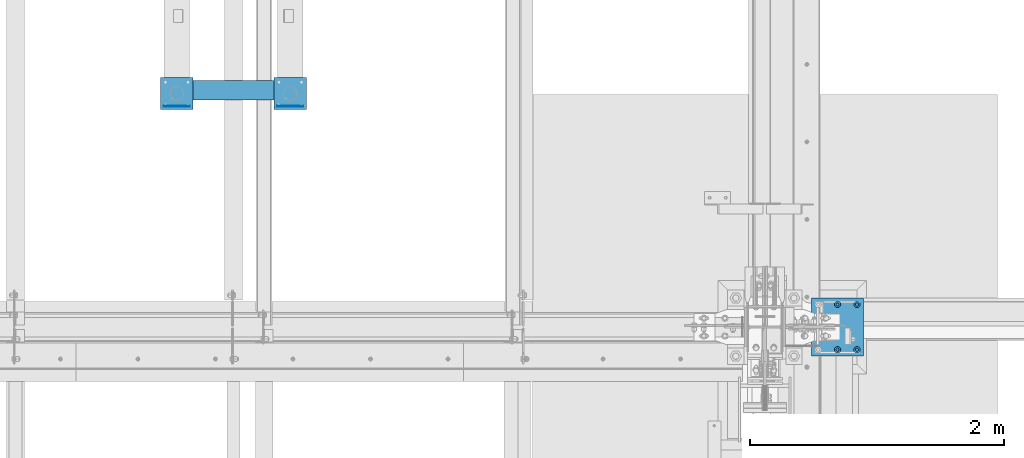
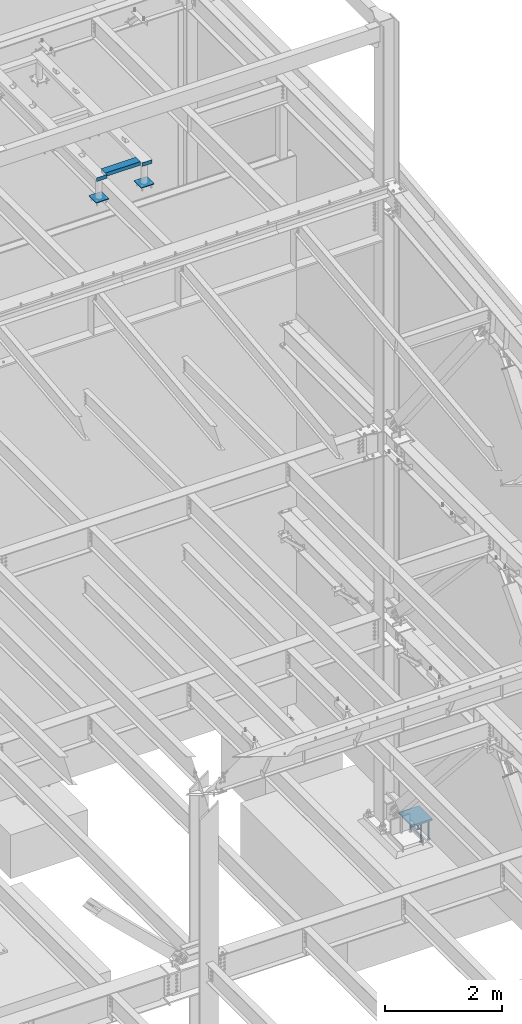
# One storey, part 900 of 1179: 10 beams, 2 elements without a shape of their own.
"""IFC2X3 building model written with IfcOpenShell, lengths in millimetres."""

from ifc_helpers import new_model, si_unit, frame, origin_with_axes, place, context, subcontext, project, spatial, faceted_brep, material, type_object, element, aggregate, save


model = new_model("IFC2X3")

# Units and contexts
model_context = context("Model", 3, precision=1e-05, world=origin_with_axes())
body_context = subcontext(model_context, "Body", "Model", "MODEL_VIEW")
ifc_project = project(units=[si_unit("LENGTHUNIT", "METRE", prefix="MILLI"), si_unit("AREAUNIT", "SQUARE_METRE"), si_unit("VOLUMEUNIT", "CUBIC_METRE"), si_unit("MASSUNIT", "GRAM", prefix="KILO"), si_unit("TIMEUNIT", "SECOND"), si_unit("PLANEANGLEUNIT", "RADIAN"), si_unit("SOLIDANGLEUNIT", "STERADIAN"), si_unit("THERMODYNAMICTEMPERATUREUNIT", "DEGREE_CELSIUS"), si_unit("LUMINOUSINTENSITYUNIT", "LUMEN")], contexts=[model_context])

# Site, building, storey
site_placement = place(None, origin_with_axes())
site = spatial("IfcSite", under=ifc_project, at=site_placement, CompositionType="ELEMENT")
building_placement = place(site_placement, origin_with_axes())
building = spatial("IfcBuilding", under=site, at=building_placement, Name="Undefined", CompositionType="ELEMENT")
storey_placement = place(building_placement, origin_with_axes())
storey = spatial("IfcBuildingStorey", under=building, at=storey_placement, Name="Undefined", CompositionType="ELEMENT", Elevation=0.0)

# Assembly, beams
assembly_1_placement = place(storey_placement, origin_with_axes())
assembly_1 = element("IfcElementAssembly", 1, at=assembly_1_placement, inside=storey, Name="FRAME", AssemblyPlace="NOTDEFINED", PredefinedType="RIGID_FRAME")
ifc_material_1 = material(Name="STEEL/A36")
beam_type_1 = type_object("IfcBeamType", PredefinedType="NOTDEFINED")
beam_1_placement = place(assembly_1_placement, frame((19581.8125, 36128.4035542222, 13722.35), z_axis=(0.0, 0.0, -1.0), x_axis=(1.0, 0.0, 0.0)))
beam_1 = element("IfcBeam", 2, at=beam_1_placement, type_object=beam_type_1, material=ifc_material_1, Name="PLATE", context=body_context, shape_type="Brep", body=[
    faceted_brep([(0.0, 2.38149999999951, -38.0999999999985), (0.0, 2.38149999999951, 38.0999999999985), (203.199999999997, 2.38150000000314, 38.1000000000004), (203.199999999997, 2.38150000000314, -38.1000000000004), (0.0, -2.38149999999951, 38.0999999999985), (203.199999999997, -2.38150000000314, 38.1000000000004), (0.0, -2.38149999999951, -38.0999999999985), (203.199999999997, -2.38150000000314, -38.1000000000004)], [[[0, 1, 2, 3]], [[1, 4, 5, 2]], [[4, 6, 7, 5]], [[6, 0, 3, 7]], [[5, 7, 3, 2]], [[6, 4, 1, 0]]]),
])
beam_2_placement = place(assembly_1_placement, frame((20473.9875, 36128.4035542222, 13722.35), z_axis=(0.0, 0.0, -1.0), x_axis=(1.0, 0.0, 0.0)))
beam_2 = element("IfcBeam", 3, at=beam_2_placement, type_object=beam_type_1, material=ifc_material_1, Name="PLATE", context=body_context, shape_type="Brep", body=[
    faceted_brep([(0.0, 2.38149999999951, -38.0999999999985), (0.0, 2.38149999999951, 38.0999999999985), (203.199999999997, 2.38150000000314, 38.1000000000004), (203.199999999997, 2.38150000000314, -38.1000000000004), (0.0, -2.38149999999951, 38.0999999999985), (203.199999999997, -2.38150000000314, 38.1000000000004), (0.0, -2.38149999999951, -38.0999999999985), (203.199999999997, -2.38150000000314, -38.1000000000004)], [[[0, 1, 2, 3]], [[1, 4, 5, 2]], [[4, 6, 7, 5]], [[6, 0, 3, 7]], [[5, 7, 3, 2]], [[6, 4, 1, 0]]]),
])
ifc_material_2 = material()
beam_type_2 = type_object("IfcBeamType", Name="HSS6X3X1/4", PredefinedType="NOTDEFINED")
beam_3_placement = place(assembly_1_placement, frame((19785.0125, 36253.0225542222, 13722.35), z_axis=(0.0, -1.0, 0.0), x_axis=(1.0, 0.0, 0.0)))
beam_3 = element("IfcBeam", 4, at=beam_3_placement, type_object=beam_type_2, material=ifc_material_2, Name="BEAM", ObjectType="HSS6X3X1/4", context=body_context, shape_type="Brep", body=[
    faceted_brep([(0.0, 31.75, -69.8499999999985), (0.0, -31.75, -69.8499999999985), (688.975000000006, -31.75, -69.8499999999985), (688.975000000006, 31.75, -69.8499999999985), (0.0, -31.75, 69.8499999999985), (688.975000000006, -31.75, 69.8499999999985), (0.0, 31.75, 69.8499999999985), (688.975000000006, 31.75, 69.8499999999985), (0.0, 38.0999999999985, -76.1999999999998), (0.0, 38.0999999999985, 76.1999999999998), (688.975000000006, 38.1000000000004, 76.1999999999971), (688.975000000006, 38.1000000000004, -76.1999999999971), (0.0, -38.0999999999985, 76.1999999999998), (688.975000000006, -38.1000000000004, 76.1999999999971), (0.0, -38.0999999999985, -76.1999999999998), (688.975000000006, -38.1000000000004, -76.1999999999971)], [[[0, 1, 2, 3]], [[1, 4, 5, 2]], [[4, 6, 7, 5]], [[6, 0, 3, 7]], [[8, 9, 10, 11]], [[9, 12, 13, 10]], [[12, 14, 15, 13]], [[14, 8, 11, 15]], [[13, 15, 11, 10], [5, 7, 3, 2]], [[14, 12, 9, 8], [6, 4, 1, 0]]]),
])
beam_type_3 = type_object("IfcBeamType", PredefinedType="NOTDEFINED")
beam_4_placement = place(assembly_1_placement, frame((20575.5875, 36100.6225542222, 13258.8), z_axis=(1.0, 0.0, 0.0), x_axis=(0.0, 1.0, 0.0)))
beam_4 = element("IfcBeam", 5, at=beam_4_placement, type_object=beam_type_3, material=ifc_material_1, Name="PLATE", context=body_context, shape_type="Brep", body=[
    faceted_brep([(0.0, 6.35000000000036, -127.0), (0.0, 6.34999999999854, 127.0), (254.0, 6.35000000000036, 127.0), (254.0, 6.35000000000036, -127.0), (0.0, -6.34999999999854, 127.0), (254.0, -6.35000000000036, 127.0), (0.0, -6.35000000000036, -127.0), (254.0, -6.35000000000036, -127.0)], [[[0, 1, 2, 3]], [[1, 4, 5, 2]], [[4, 6, 7, 5]], [[6, 0, 3, 7]], [[5, 7, 3, 2]], [[6, 4, 1, 0]]]),
])
beam_5_placement = place(assembly_1_placement, frame((19683.4125, 36100.6225542222, 13258.8), z_axis=(1.0, 0.0, 0.0), x_axis=(0.0, 1.0, 0.0)))
beam_5 = element("IfcBeam", 6, at=beam_5_placement, type_object=beam_type_3, material=ifc_material_1, Name="PLATE", context=body_context, shape_type="Brep", body=[
    faceted_brep([(0.0, 6.35000000000036, -127.0), (0.0, 6.34999999999854, 127.0), (254.0, 6.35000000000036, 127.0), (254.0, 6.35000000000036, -127.0), (0.0, -6.34999999999854, 127.0), (254.0, -6.35000000000036, 127.0), (0.0, -6.35000000000036, -127.0), (254.0, -6.35000000000036, -127.0)], [[[0, 1, 2, 3]], [[1, 4, 5, 2]], [[4, 6, 7, 5]], [[6, 0, 3, 7]], [[5, 7, 3, 2]], [[6, 4, 1, 0]]]),
])
aggregate(assembly_1, [beam_3, beam_1, beam_2, beam_4, beam_5])

assembly_2_placement = place(storey_placement, origin_with_axes())
assembly_2 = element("IfcElementAssembly", 7, at=assembly_2_placement, inside=storey, Name="EMBED_PLATE", AssemblyPlace="NOTDEFINED", PredefinedType="RIGID_FRAME")
ifc_material_3 = material(Name="STEEL/A108")
beam_type_4 = type_object("IfcBeamType", Name="STUD_1-DIA", PredefinedType="NOTDEFINED")
beam_6_placement = place(assembly_2_placement, frame((25031.7, 34569.4, -393.700006103516), z_axis=(1.0, 0.0, 0.0), x_axis=(0.0, 0.0, -1.0)))
beam_6 = element("IfcBeam", 8, at=beam_6_placement, type_object=beam_type_4, material=ifc_material_3, Name="STUD", ObjectType="STUD_1-DIA", context=body_context, shape_type="Brep", body=[
    faceted_brep([(0.0, -12.7, 0.0), (0.0, -11.0, -6.34999990463257), (382.016, -11.0, -6.34999990463257), (382.016, -12.6999998092651, 0.0), (0.0, -6.34999990463257, -11.0), (382.016, -6.34999990463257, -11.0), (0.0, 0.0, -12.6999998092651), (382.016, 0.0, -12.6999998092651), (0.0, 6.34999990463257, -11.0), (382.016, 6.34999990463257, -11.0), (0.0, 11.0, -6.34999990463257), (382.016, 11.0, -6.34999990463257), (0.0, 12.7, 0.0), (382.016, 12.6999998092651, 0.0), (0.0, 11.0, 6.34999990463257), (382.016, 11.0, 6.34999990463257), (0.0, 6.34999990463257, 11.0), (382.016, 6.34999990463257, 11.0), (0.0, 0.0, 12.6999998092651), (382.016, 0.0, 12.6999998092651), (0.0, -6.34999990463257, 11.0), (382.016, -6.34999990463257, 11.0), (0.0, -11.0, 6.34999990463257), (382.016, -11.0, 6.34999990463257), (386.08, -22.0, -12.6999998092651), (386.08, -25.3999996185303, 0.0), (386.08, -12.6999998092651, -22.0), (386.08, 0.0, -25.3999996185303), (386.08, 12.6999998092651, -22.0), (386.08, 22.0, -12.6999998092651), (386.08, 25.3999996185303, 0.0), (386.08, 22.0, 12.6999998092651), (386.08, 12.6999998092651, 22.0), (386.08, 0.0, 25.3999996185303), (386.08, -12.6999998092651, 22.0), (386.08, -22.0, 12.6999998092651), (406.4, -22.0, -12.6999998092651), (406.4, -25.3999996185303, 0.0), (406.4, -12.6999998092651, -22.0), (406.4, 0.0, -25.3999996185303), (406.4, 12.6999998092651, -22.0), (406.4, 22.0, -12.6999998092651), (406.4, 25.3999996185303, 0.0), (406.4, 22.0, 12.6999998092651), (406.4, 12.6999998092651, 22.0), (406.4, 0.0, 25.3999996185303), (406.4, -12.6999998092651, 22.0), (406.4, -22.0, 12.6999998092651)], [[[0, 1, 2, 3]], [[1, 4, 5, 2]], [[4, 6, 7, 5]], [[6, 8, 9, 7]], [[8, 10, 11, 9]], [[10, 12, 13, 11]], [[12, 14, 15, 13]], [[14, 16, 17, 15]], [[16, 18, 19, 17]], [[18, 20, 21, 19]], [[20, 22, 23, 21]], [[22, 0, 3, 23]], [[22, 20, 18, 16, 14, 12, 10, 8, 6, 4, 1, 0]], [[3, 2, 24, 25]], [[2, 5, 26, 24]], [[5, 7, 27, 26]], [[7, 9, 28, 27]], [[9, 11, 29, 28]], [[11, 13, 30, 29]], [[13, 15, 31, 30]], [[15, 17, 32, 31]], [[17, 19, 33, 32]], [[19, 21, 34, 33]], [[21, 23, 35, 34]], [[23, 3, 25, 35]], [[25, 24, 36, 37]], [[24, 26, 38, 36]], [[26, 27, 39, 38]], [[27, 28, 40, 39]], [[28, 29, 41, 40]], [[29, 30, 42, 41]], [[30, 31, 43, 42]], [[31, 32, 44, 43]], [[32, 33, 45, 44]], [[33, 34, 46, 45]], [[34, 35, 47, 46]], [[35, 25, 37, 47]], [[38, 39, 40, 41, 42, 43, 44, 45, 46, 47, 37, 36]]]),
])
beam_7_placement = place(assembly_2_placement, frame((24879.3, 34569.4, -393.700006103516), z_axis=(1.0, 0.0, 0.0), x_axis=(0.0, 0.0, -1.0)))
beam_7 = element("IfcBeam", 9, at=beam_7_placement, type_object=beam_type_4, material=ifc_material_3, Name="STUD", ObjectType="STUD_1-DIA", context=body_context, shape_type="Brep", body=[
    faceted_brep([(0.0, -12.7, 0.0), (0.0, -11.0, -6.34999990463257), (382.016, -11.0, -6.34999990463257), (382.016, -12.6999998092651, 0.0), (0.0, -6.34999990463257, -11.0), (382.016, -6.34999990463257, -11.0), (0.0, 0.0, -12.6999998092651), (382.016, 0.0, -12.6999998092651), (0.0, 6.34999990463257, -11.0), (382.016, 6.34999990463257, -11.0), (0.0, 11.0, -6.34999990463257), (382.016, 11.0, -6.34999990463257), (0.0, 12.7, 0.0), (382.016, 12.6999998092651, 0.0), (0.0, 11.0, 6.34999990463257), (382.016, 11.0, 6.34999990463257), (0.0, 6.34999990463257, 11.0), (382.016, 6.34999990463257, 11.0), (0.0, 0.0, 12.6999998092651), (382.016, 0.0, 12.6999998092651), (0.0, -6.34999990463257, 11.0), (382.016, -6.34999990463257, 11.0), (0.0, -11.0, 6.34999990463257), (382.016, -11.0, 6.34999990463257), (386.08, -22.0, -12.6999998092651), (386.08, -25.3999996185303, 0.0), (386.08, -12.6999998092651, -22.0), (386.08, 0.0, -25.3999996185303), (386.08, 12.6999998092651, -22.0), (386.08, 22.0, -12.6999998092651), (386.08, 25.3999996185303, 0.0), (386.08, 22.0, 12.6999998092651), (386.08, 12.6999998092651, 22.0), (386.08, 0.0, 25.3999996185303), (386.08, -12.6999998092651, 22.0), (386.08, -22.0, 12.6999998092651), (406.4, -22.0, -12.6999998092651), (406.4, -25.3999996185303, 0.0), (406.4, -12.6999998092651, -22.0), (406.4, 0.0, -25.3999996185303), (406.4, 12.6999998092651, -22.0), (406.4, 22.0, -12.6999998092651), (406.4, 25.3999996185303, 0.0), (406.4, 22.0, 12.6999998092651), (406.4, 12.6999998092651, 22.0), (406.4, 0.0, 25.3999996185303), (406.4, -12.6999998092651, 22.0), (406.4, -22.0, 12.6999998092651)], [[[0, 1, 2, 3]], [[1, 4, 5, 2]], [[4, 6, 7, 5]], [[6, 8, 9, 7]], [[8, 10, 11, 9]], [[10, 12, 13, 11]], [[12, 14, 15, 13]], [[14, 16, 17, 15]], [[16, 18, 19, 17]], [[18, 20, 21, 19]], [[20, 22, 23, 21]], [[22, 0, 3, 23]], [[22, 20, 18, 16, 14, 12, 10, 8, 6, 4, 1, 0]], [[3, 2, 24, 25]], [[2, 5, 26, 24]], [[5, 7, 27, 26]], [[7, 9, 28, 27]], [[9, 11, 29, 28]], [[11, 13, 30, 29]], [[13, 15, 31, 30]], [[15, 17, 32, 31]], [[17, 19, 33, 32]], [[19, 21, 34, 33]], [[21, 23, 35, 34]], [[23, 3, 25, 35]], [[25, 24, 36, 37]], [[24, 26, 38, 36]], [[26, 27, 39, 38]], [[27, 28, 40, 39]], [[28, 29, 41, 40]], [[29, 30, 42, 41]], [[30, 31, 43, 42]], [[31, 32, 44, 43]], [[32, 33, 45, 44]], [[33, 34, 46, 45]], [[34, 35, 47, 46]], [[35, 25, 37, 47]], [[38, 39, 40, 41, 42, 43, 44, 45, 46, 47, 37, 36]]]),
])
beam_8_placement = place(assembly_2_placement, frame((25031.7, 34213.8, -393.700006103516), z_axis=(1.0, 0.0, 0.0), x_axis=(0.0, 0.0, -1.0)))
beam_8 = element("IfcBeam", 10, at=beam_8_placement, type_object=beam_type_4, material=ifc_material_3, Name="STUD", ObjectType="STUD_1-DIA", context=body_context, shape_type="Brep", body=[
    faceted_brep([(0.0, -12.7, 0.0), (0.0, -11.0, -6.34999990463257), (382.016, -11.0, -6.34999990463257), (382.016, -12.6999998092651, 0.0), (0.0, -6.34999990463257, -11.0), (382.016, -6.34999990463257, -11.0), (0.0, 0.0, -12.6999998092651), (382.016, 0.0, -12.6999998092651), (0.0, 6.34999990463257, -11.0), (382.016, 6.34999990463257, -11.0), (0.0, 11.0, -6.34999990463257), (382.016, 11.0, -6.34999990463257), (0.0, 12.7, 0.0), (382.016, 12.6999998092651, 0.0), (0.0, 11.0, 6.34999990463257), (382.016, 11.0, 6.34999990463257), (0.0, 6.34999990463257, 11.0), (382.016, 6.34999990463257, 11.0), (0.0, 0.0, 12.6999998092651), (382.016, 0.0, 12.6999998092651), (0.0, -6.34999990463257, 11.0), (382.016, -6.34999990463257, 11.0), (0.0, -11.0, 6.34999990463257), (382.016, -11.0, 6.34999990463257), (386.08, -22.0, -12.6999998092651), (386.08, -25.3999996185303, 0.0), (386.08, -12.6999998092651, -22.0), (386.08, 0.0, -25.3999996185303), (386.08, 12.6999998092651, -22.0), (386.08, 22.0, -12.6999998092651), (386.08, 25.3999996185303, 0.0), (386.08, 22.0, 12.6999998092651), (386.08, 12.6999998092651, 22.0), (386.08, 0.0, 25.3999996185303), (386.08, -12.6999998092651, 22.0), (386.08, -22.0, 12.6999998092651), (406.4, -22.0, -12.6999998092651), (406.4, -25.3999996185303, 0.0), (406.4, -12.6999998092651, -22.0), (406.4, 0.0, -25.3999996185303), (406.4, 12.6999998092651, -22.0), (406.4, 22.0, -12.6999998092651), (406.4, 25.3999996185303, 0.0), (406.4, 22.0, 12.6999998092651), (406.4, 12.6999998092651, 22.0), (406.4, 0.0, 25.3999996185303), (406.4, -12.6999998092651, 22.0), (406.4, -22.0, 12.6999998092651)], [[[0, 1, 2, 3]], [[1, 4, 5, 2]], [[4, 6, 7, 5]], [[6, 8, 9, 7]], [[8, 10, 11, 9]], [[10, 12, 13, 11]], [[12, 14, 15, 13]], [[14, 16, 17, 15]], [[16, 18, 19, 17]], [[18, 20, 21, 19]], [[20, 22, 23, 21]], [[22, 0, 3, 23]], [[22, 20, 18, 16, 14, 12, 10, 8, 6, 4, 1, 0]], [[3, 2, 24, 25]], [[2, 5, 26, 24]], [[5, 7, 27, 26]], [[7, 9, 28, 27]], [[9, 11, 29, 28]], [[11, 13, 30, 29]], [[13, 15, 31, 30]], [[15, 17, 32, 31]], [[17, 19, 33, 32]], [[19, 21, 34, 33]], [[21, 23, 35, 34]], [[23, 3, 25, 35]], [[25, 24, 36, 37]], [[24, 26, 38, 36]], [[26, 27, 39, 38]], [[27, 28, 40, 39]], [[28, 29, 41, 40]], [[29, 30, 42, 41]], [[30, 31, 43, 42]], [[31, 32, 44, 43]], [[32, 33, 45, 44]], [[33, 34, 46, 45]], [[34, 35, 47, 46]], [[35, 25, 37, 47]], [[38, 39, 40, 41, 42, 43, 44, 45, 46, 47, 37, 36]]]),
])
beam_9_placement = place(assembly_2_placement, frame((24879.3, 34213.8, -393.700006103516), z_axis=(1.0, 0.0, 0.0), x_axis=(0.0, 0.0, -1.0)))
beam_9 = element("IfcBeam", 11, at=beam_9_placement, type_object=beam_type_4, material=ifc_material_3, Name="STUD", ObjectType="STUD_1-DIA", context=body_context, shape_type="Brep", body=[
    faceted_brep([(0.0, -12.7, 0.0), (0.0, -11.0, -6.34999990463257), (382.016, -11.0, -6.34999990463257), (382.016, -12.6999998092651, 0.0), (0.0, -6.34999990463257, -11.0), (382.016, -6.34999990463257, -11.0), (0.0, 0.0, -12.6999998092651), (382.016, 0.0, -12.6999998092651), (0.0, 6.34999990463257, -11.0), (382.016, 6.34999990463257, -11.0), (0.0, 11.0, -6.34999990463257), (382.016, 11.0, -6.34999990463257), (0.0, 12.7, 0.0), (382.016, 12.6999998092651, 0.0), (0.0, 11.0, 6.34999990463257), (382.016, 11.0, 6.34999990463257), (0.0, 6.34999990463257, 11.0), (382.016, 6.34999990463257, 11.0), (0.0, 0.0, 12.6999998092651), (382.016, 0.0, 12.6999998092651), (0.0, -6.34999990463257, 11.0), (382.016, -6.34999990463257, 11.0), (0.0, -11.0, 6.34999990463257), (382.016, -11.0, 6.34999990463257), (386.08, -22.0, -12.6999998092651), (386.08, -25.3999996185303, 0.0), (386.08, -12.6999998092651, -22.0), (386.08, 0.0, -25.3999996185303), (386.08, 12.6999998092651, -22.0), (386.08, 22.0, -12.6999998092651), (386.08, 25.3999996185303, 0.0), (386.08, 22.0, 12.6999998092651), (386.08, 12.6999998092651, 22.0), (386.08, 0.0, 25.3999996185303), (386.08, -12.6999998092651, 22.0), (386.08, -22.0, 12.6999998092651), (406.4, -22.0, -12.6999998092651), (406.4, -25.3999996185303, 0.0), (406.4, -12.6999998092651, -22.0), (406.4, 0.0, -25.3999996185303), (406.4, 12.6999998092651, -22.0), (406.4, 22.0, -12.6999998092651), (406.4, 25.3999996185303, 0.0), (406.4, 22.0, 12.6999998092651), (406.4, 12.6999998092651, 22.0), (406.4, 0.0, 25.3999996185303), (406.4, -12.6999998092651, 22.0), (406.4, -22.0, 12.6999998092651)], [[[0, 1, 2, 3]], [[1, 4, 5, 2]], [[4, 6, 7, 5]], [[6, 8, 9, 7]], [[8, 10, 11, 9]], [[10, 12, 13, 11]], [[12, 14, 15, 13]], [[14, 16, 17, 15]], [[16, 18, 19, 17]], [[18, 20, 21, 19]], [[20, 22, 23, 21]], [[22, 0, 3, 23]], [[22, 20, 18, 16, 14, 12, 10, 8, 6, 4, 1, 0]], [[3, 2, 24, 25]], [[2, 5, 26, 24]], [[5, 7, 27, 26]], [[7, 9, 28, 27]], [[9, 11, 29, 28]], [[11, 13, 30, 29]], [[13, 15, 31, 30]], [[15, 17, 32, 31]], [[17, 19, 33, 32]], [[19, 21, 34, 33]], [[21, 23, 35, 34]], [[23, 3, 25, 35]], [[25, 24, 36, 37]], [[24, 26, 38, 36]], [[26, 27, 39, 38]], [[27, 28, 40, 39]], [[28, 29, 41, 40]], [[29, 30, 42, 41]], [[30, 31, 43, 42]], [[31, 32, 44, 43]], [[32, 33, 45, 44]], [[33, 34, 46, 45]], [[34, 35, 47, 46]], [[35, 25, 37, 47]], [[38, 39, 40, 41, 42, 43, 44, 45, 46, 47, 37, 36]]]),
])
ifc_material_4 = material(Name="STEEL/A572-GR.50")
beam_type_5 = type_object("IfcBeamType", PredefinedType="NOTDEFINED")
beam_10_placement = place(assembly_2_placement, frame((24676.1, 34391.6, -374.650006103515), z_axis=(0.0, 1.0, 0.0), x_axis=(1.0, 0.0, 0.0)))
beam_10 = element("IfcBeam", 12, at=beam_10_placement, type_object=beam_type_5, material=ifc_material_4, Name="EMBED_PLATE", context=body_context, shape_type="Brep", body=[
    faceted_brep([(0.0, 19.05, -228.6), (0.0, 19.05, 228.6), (406.400000000001, 19.05, 228.6), (406.400000000001, 19.05, -228.6), (0.0, -19.05, 228.6), (406.400000000001, -19.05, 228.6), (0.0, -19.05, -228.6), (406.400000000001, -19.05, -228.6)], [[[0, 1, 2, 3]], [[1, 4, 5, 2]], [[4, 6, 7, 5]], [[6, 0, 3, 7]], [[5, 7, 3, 2]], [[6, 4, 1, 0]]]),
])
aggregate(assembly_2, [beam_6, beam_7, beam_8, beam_9, beam_10])

save(model, "model.ifc")
